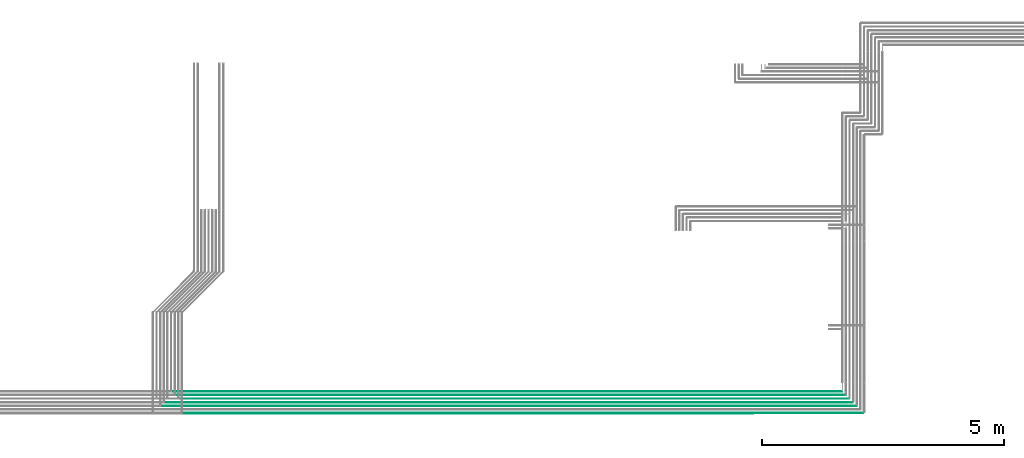
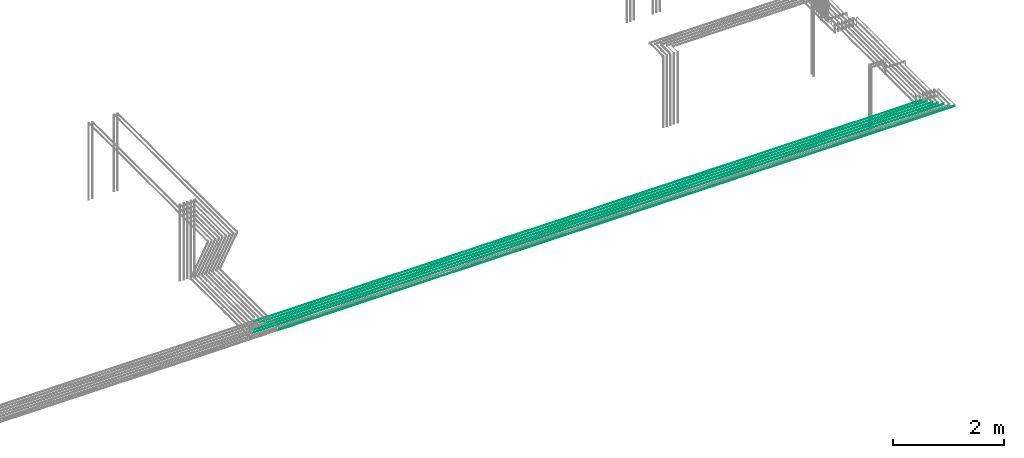
# One storey, part 15 of 89: 6 flow segments.
"""IFC2X3 building model written with IfcOpenShell, lengths in millimetres."""

from ifc_helpers import new_model, entity, si_unit, converted_unit, derived_unit, direction, frame, frame_2d, origin, place, context, subcontext, project, spatial, circle, extrude, type_object, element, save


model = new_model("IFC2X3")

# Units and contexts
model_context = context("Model", 3, precision=0.01, world=origin(), true_north=direction((6.12303176911189e-17, 1.0)))
body_context = subcontext(model_context, "Body", "Model", "MODEL_VIEW")
ifc_project = project(units=[si_unit("LENGTHUNIT", "METRE", prefix="MILLI"), si_unit("AREAUNIT", "SQUARE_METRE"), si_unit("VOLUMEUNIT", "CUBIC_METRE"), converted_unit("PLANEANGLEUNIT", "DEGREE", entity("IfcRatioMeasure", 0.0174532925199433), si_unit("PLANEANGLEUNIT", "RADIAN"), dimensions=[0, 0, 0, 0, 0, 0, 0]), si_unit("MASSUNIT", "GRAM", prefix="KILO"), derived_unit("MASSDENSITYUNIT", [(si_unit("MASSUNIT", "GRAM", prefix="KILO"), 1), (si_unit("LENGTHUNIT", "METRE"), -3)]), derived_unit("MOMENTOFINERTIAUNIT", [(si_unit("LENGTHUNIT", "METRE"), 4)]), si_unit("TIMEUNIT", "SECOND"), si_unit("FREQUENCYUNIT", "HERTZ"), si_unit("THERMODYNAMICTEMPERATUREUNIT", "DEGREE_CELSIUS"), derived_unit("THERMALTRANSMITTANCEUNIT", [(si_unit("MASSUNIT", "GRAM", prefix="KILO"), 1), (si_unit("THERMODYNAMICTEMPERATUREUNIT", "KELVIN"), -1), (si_unit("TIMEUNIT", "SECOND"), -3)]), derived_unit("VOLUMETRICFLOWRATEUNIT", [(si_unit("LENGTHUNIT", "METRE"), 3), (si_unit("TIMEUNIT", "SECOND"), -1)]), derived_unit("MASSFLOWRATEUNIT", [(si_unit("MASSUNIT", "GRAM", prefix="KILO"), 1), (si_unit("TIMEUNIT", "SECOND"), -1)]), derived_unit("ROTATIONALFREQUENCYUNIT", [(si_unit("TIMEUNIT", "SECOND"), -1)]), si_unit("ELECTRICCURRENTUNIT", "AMPERE"), si_unit("ELECTRICVOLTAGEUNIT", "VOLT"), si_unit("POWERUNIT", "WATT"), si_unit("FORCEUNIT", "NEWTON", prefix="KILO"), si_unit("ILLUMINANCEUNIT", "LUX"), si_unit("LUMINOUSFLUXUNIT", "LUMEN"), si_unit("LUMINOUSINTENSITYUNIT", "CANDELA"), derived_unit("USERDEFINED", [(si_unit("MASSUNIT", "GRAM", prefix="KILO"), -1), (si_unit("LENGTHUNIT", "METRE"), -2), (si_unit("TIMEUNIT", "SECOND"), 3), (si_unit("LUMINOUSFLUXUNIT", "LUMEN"), 1)]), derived_unit("LINEARVELOCITYUNIT", [(si_unit("LENGTHUNIT", "METRE"), 1), (si_unit("TIMEUNIT", "SECOND"), -1)]), si_unit("PRESSUREUNIT", "PASCAL"), derived_unit("USERDEFINED", [(si_unit("LENGTHUNIT", "METRE"), -2), (si_unit("MASSUNIT", "GRAM", prefix="KILO"), 1), (si_unit("TIMEUNIT", "SECOND"), -2)]), derived_unit("LINEARFORCEUNIT", [(si_unit("MASSUNIT", "GRAM", prefix="KILO"), 1), (si_unit("LENGTHUNIT", "METRE"), 1), (si_unit("TIMEUNIT", "SECOND"), -2), (si_unit("LENGTHUNIT", "METRE"), -1)]), derived_unit("PLANARFORCEUNIT", [(si_unit("MASSUNIT", "GRAM", prefix="KILO"), 1), (si_unit("LENGTHUNIT", "METRE"), 1), (si_unit("TIMEUNIT", "SECOND"), -2), (si_unit("LENGTHUNIT", "METRE"), -2)])], contexts=[model_context])

# Site, building, storey
site_placement = place(None, frame((0.0, -0.00077364408347762, 0.0)))
site = spatial("IfcSite", under=ifc_project, at=site_placement, CompositionType="ELEMENT")
building_placement = place(site_placement, origin())
building = spatial("IfcBuilding", under=site, at=building_placement, CompositionType="ELEMENT")
storey_placement = place(building_placement, frame((0.0, 0.0, 24000.0)))
storey = spatial("IfcBuildingStorey", under=building, at=storey_placement, CompositionType="ELEMENT", Elevation=24000.0)

# Flow segments
pipe_segment_type = type_object("IfcPipeSegmentType", PredefinedType="NOTDEFINED")
flow_segment_1_placement = place(storey_placement, frame((53599.1933873496, 1165.8560272999, 2990.90472776409)))
element("IfcFlowSegment", 1, at=flow_segment_1_placement, inside=storey, type_object=pipe_segment_type, context=body_context, shape_type="SweptSolid", body=[
    extrude(circle(Radius=7.5, at=frame_2d((-1.89501747627219e-12, 0.0), x_axis=(1.0, 0.0))), frame((0.0, 9.09527223591799, 9.09527223591419), z_axis=(1.0, 0.0, 0.0), x_axis=(0.0, 1.0, 0.0)), (0.0, 0.0, 1.0), 14052.8068812052),
])
flow_segment_2_placement = place(storey_placement, frame((53146.1933873496, 1319.35602729994, 2994.40472776409)))
element("IfcFlowSegment", 2, at=flow_segment_2_placement, inside=storey, type_object=pipe_segment_type, context=body_context, shape_type="SweptSolid", body=[
    extrude(circle(Radius=4.0, at=frame_2d((-1.89501747627219e-12, 0.0), x_axis=(1.0, 0.0))), frame((0.0, 5.5952722359177, 5.59527223591499), z_axis=(1.0, 0.0, 0.0), x_axis=(0.0, 1.0, 0.0)), (0.0, 0.0, 1.0), 14363.8068812052),
])
flow_segment_3_placement = place(storey_placement, frame((53221.6006808591, 1394.35602729991, 2994.40472776409)))
element("IfcFlowSegment", 3, at=flow_segment_3_placement, inside=storey, type_object=pipe_segment_type, context=body_context, shape_type="SweptSolid", body=[
    extrude(circle(Radius=4.0, at=frame_2d((-1.89501747627219e-12, 0.0), x_axis=(1.0, 0.0))), frame((0.0, 5.5952722359177, 5.59527223591499), z_axis=(1.0, 0.0, 0.0), x_axis=(0.0, 1.0, 0.0)), (0.0, 0.0, 1.0), 14213.3995876958),
])
for number, where in (
    (4, (53371.1933873496, 1619.35602729995, 2994.40472776409)),
    (5, (53446.1933873496, 1544.35602729992, 2994.40472776409)),
    (6, (53521.1933873496, 1469.35602729994, 2994.40472776409)),
):
    element("IfcFlowSegment", number, at=place(storey_placement, frame(where)), inside=storey, type_object=pipe_segment_type, context=body_context, shape_type="SweptSolid", body=[
        extrude(circle(Radius=4.0, at=frame_2d((-1.89501747627219e-12, 0.0), x_axis=(1.0, 0.0))), frame((0.0, 5.5952722359177, 5.59527223591499), z_axis=(1.0, 0.0, 0.0), x_axis=(0.0, 1.0, 0.0)), (0.0, 0.0, 1.0), 13838.8068812052),
    ])

save(model, "model.ifc")
